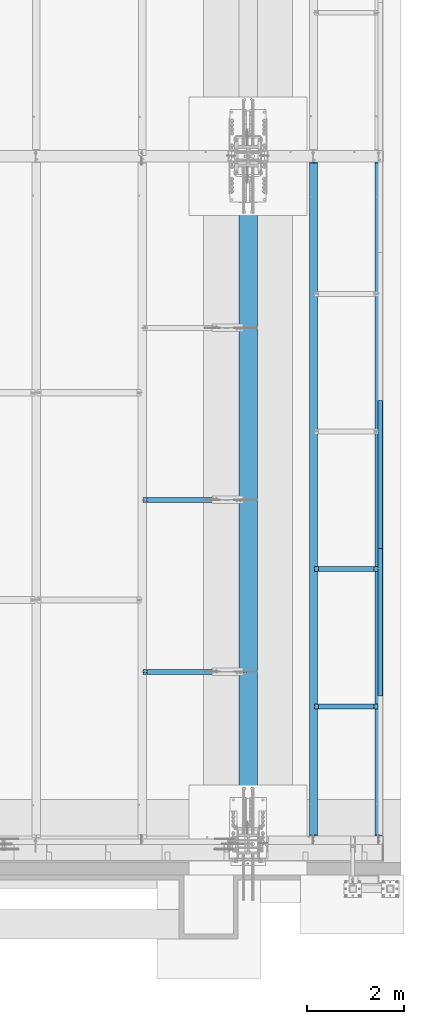
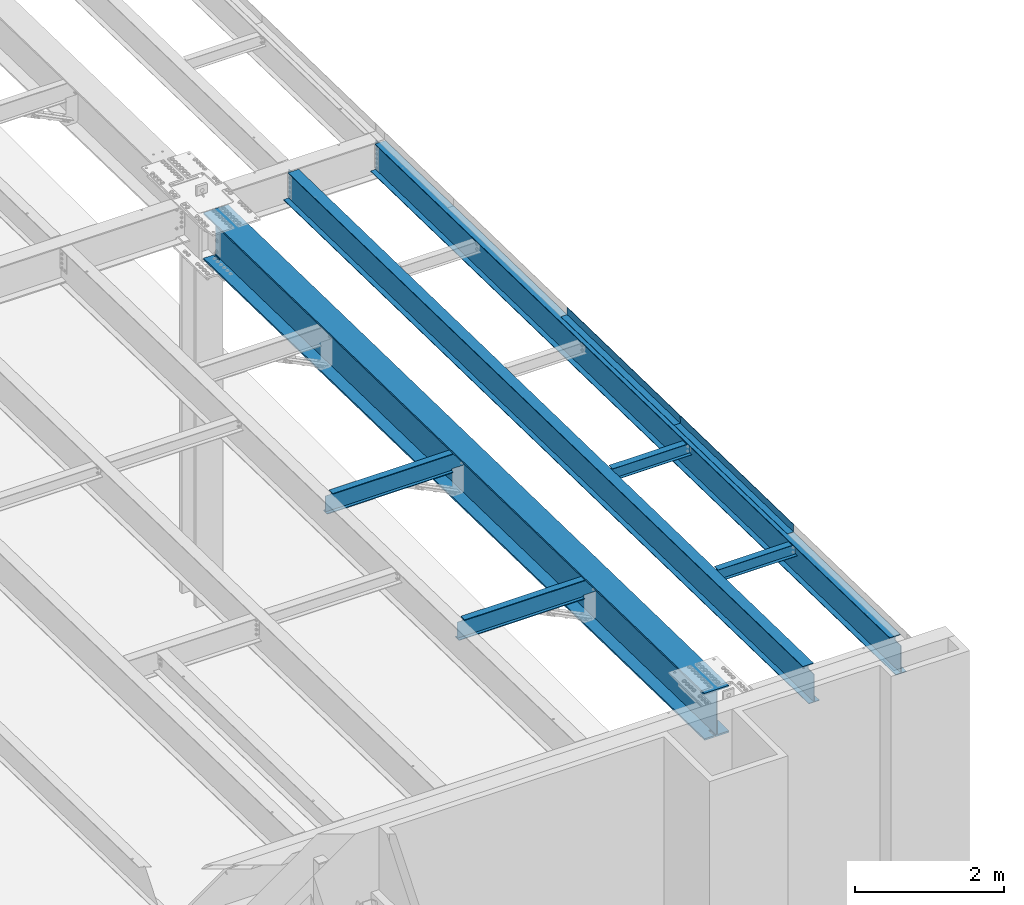
# One storey, part 1113 of 1763: 9 beams, 7 elements without a shape of their own.
"""IFC2X3 building model written with IfcOpenShell, lengths in millimetres."""

from ifc_helpers import new_model, si_unit, frame, origin_with_axes, place, context, subcontext, project, spatial, faceted_brep, material, type_object, element, aggregate, save


model = new_model("IFC2X3")

# Units and contexts
model_context = context("Model", 3, precision=1e-05, world=origin_with_axes())
body_context = subcontext(model_context, "Body", "Model", "MODEL_VIEW")
ifc_project = project(units=[si_unit("LENGTHUNIT", "METRE", prefix="MILLI"), si_unit("AREAUNIT", "SQUARE_METRE"), si_unit("VOLUMEUNIT", "CUBIC_METRE"), si_unit("MASSUNIT", "GRAM", prefix="KILO"), si_unit("TIMEUNIT", "SECOND"), si_unit("PLANEANGLEUNIT", "RADIAN"), si_unit("SOLIDANGLEUNIT", "STERADIAN"), si_unit("THERMODYNAMICTEMPERATUREUNIT", "DEGREE_CELSIUS"), si_unit("LUMINOUSINTENSITYUNIT", "LUMEN")], contexts=[model_context])

# Site, building, storey
site_placement = place(None, origin_with_axes())
site = spatial("IfcSite", under=ifc_project, at=site_placement, CompositionType="ELEMENT")
building_placement = place(site_placement, origin_with_axes())
building = spatial("IfcBuilding", under=site, at=building_placement, Name="Undefined", CompositionType="ELEMENT")
storey_placement = place(building_placement, origin_with_axes())
storey = spatial("IfcBuildingStorey", under=building, at=storey_placement, Name="Undefined", CompositionType="ELEMENT", Elevation=0.0)

# Assembly, beams
assembly_1_placement = place(storey_placement, origin_with_axes())
assembly_1 = element("IfcElementAssembly", 1, at=assembly_1_placement, inside=storey, Name="BEAM", AssemblyPlace="NOTDEFINED", PredefinedType="RIGID_FRAME")
ifc_material_1 = material(Name="STEEL/A36")
beam_type_1 = type_object("IfcBeamType", PredefinedType="NOTDEFINED")
beam_1_placement = place(assembly_1_placement, frame((-21348.1372736984, -6097.05363137779, 12048.5945885231), z_axis=(0.0, -0.999781542838788, 0.0209013539966307), x_axis=(1.0, 0.0, 0.0)))
beam_1 = element("IfcBeam", 2, at=beam_1_placement, type_object=beam_type_1, material=ifc_material_1, Name="BENT_PLATE", context=body_context, shape_type="Brep", body=[
    faceted_brep([(0.0, -3.17499999999927, -1523.99999999999), (0.0, -3.17499999999927, 1524.0), (0.0, 3.17499999999927, 1524.0), (0.0, 3.17499999999927, -1523.99999999999), (95.2499984741262, 3.17499999910251, 1523.99999999978), (95.2499984741262, 3.17500000090149, -1523.99999999977), (101.599998474125, -3.17499999909887, -1523.99999999978), (101.599999809252, -3.17500000000655, 1524.0), (95.2499984741262, 123.825003587437, 1523.99999999985), (95.2499984741262, 123.825003589236, -1523.9999999997), (101.599998474125, 123.825003587437, 1523.99999999985), (101.599998474125, 123.825003589236, -1523.9999999997)], [[[0, 1, 2, 3]], [[3, 2, 4, 5]], [[1, 0, 6, 7]], [[5, 4, 8, 9]], [[4, 2, 1, 7, 10, 8]], [[7, 6, 11, 10]], [[6, 0, 3, 5, 9, 11]], [[10, 11, 9, 8]]]),
])
beam_2_placement = place(assembly_1_placement, frame((-21348.1372736984, -9144.38777382545, 12112.3019215993), z_axis=(0.0, -0.999781542838788, 0.0209013539966307), x_axis=(1.0, 0.0, 0.0)))
beam_2 = element("IfcBeam", 3, at=beam_2_placement, type_object=beam_type_1, material=ifc_material_1, Name="BENT_PLATE", context=body_context, shape_type="Brep", body=[
    faceted_brep([(0.0, -3.17499999999927, -1523.99999999999), (0.0, -3.17499999999927, 1524.0), (0.0, 3.17499999999927, 1524.0), (0.0, 3.17499999999927, -1523.99999999999), (95.2499984741262, 3.17499999910251, 1523.99999999978), (95.2499984741262, 3.17500000090149, -1523.99999999977), (101.599998474125, -3.17499999909887, -1523.99999999978), (101.599999809252, -3.17500000000655, 1524.0), (95.2499984741262, 123.825003587437, 1523.99999999985), (95.2499984741262, 123.825003589236, -1523.9999999997), (101.599998474125, 123.825003587437, 1523.99999999985), (101.599998474125, 123.825003589236, -1523.9999999997)], [[[0, 1, 2, 3]], [[3, 2, 4, 5]], [[1, 0, 6, 7]], [[5, 4, 8, 9]], [[4, 2, 1, 7, 10, 8]], [[7, 6, 11, 10]], [[6, 0, 3, 5, 9, 11]], [[10, 11, 9, 8]]]),
])

# Assembly, beam
assembly_2_placement = place(storey_placement, origin_with_axes())
assembly_2 = element("IfcElementAssembly", 4, at=assembly_2_placement, inside=storey, Name="BEAM", AssemblyPlace="NOTDEFINED", PredefinedType="RIGID_FRAME")
ifc_material_2 = material(Name="STEEL/A992")
beam_type_2 = type_object("IfcBeamType", Name="W8X10", PredefinedType="NOTDEFINED")
beam_3_placement = place(assembly_2_placement, frame((-22678.4622736984, -10881.36, 12045.4267355389), z_axis=(0.0, 0.0, 1.0), x_axis=(1.0, 0.0, 0.0)))
beam_3 = element("IfcBeam", 5, at=beam_3_placement, type_object=beam_type_2, material=ifc_material_2, Name="BEAM", ObjectType="W8X10", context=body_context, shape_type="Brep", body=[
    faceted_brep([(1249.3625, -50.7999999999993, 100.012500000001), (1249.3625, -50.7999999999993, 95.25), (1249.3625, -2.38125000000036, 95.25), (1249.3625, -2.38125000000036, 87.0525014841896), (1249.3625, 2.38125000000036, 87.0525014841896), (1249.3625, 2.38125000000036, 95.25), (1249.3625, 50.7999999999993, 95.25), (1249.3625, 50.7999999999993, 100.012500000001), (1250.32922992258, -2.38125000000036, 82.1924219661432), (1250.32922992258, 2.38125000000036, 82.1924219661432), (1253.08224382306, -2.38125000000036, 78.0722454979896), (1253.08224382306, 2.38125000000036, 78.0722454979896), (1257.20242029121, -2.38125000000036, 75.319231597512), (1257.20242029121, 2.38125000000036, 75.319231597512), (1262.06249980926, -2.38125000000036, 74.3525016749245), (1262.06249980926, 2.38125000000036, 74.3525016749245), (1331.91249999999, -2.38125000000036, 74.3525016749245), (1331.91249999999, 2.38125000000036, 74.3525016749245), (100.012500000012, -50.7999999999993, 100.012500000001), (100.012500000012, 50.7999999999993, 100.012500000001), (100.012500000012, 50.7999999999993, 95.25), (100.012500000012, 2.38124999999854, 95.25), (100.012499999993, 2.38125000000036, 87.0525014841896), (100.012499999993, -2.38125000000036, 87.0525014841896), (100.012500000012, -2.38124999999854, 95.25), (100.012500000012, -50.7999999999993, 95.25), (99.0457700774059, 2.38125000000036, 82.1924219661432), (99.0457700774059, -2.38125000000036, 82.1924219661432), (96.2927561769284, 2.38125000000036, 78.0722454979896), (96.2927561769284, -2.38125000000036, 78.0722454979896), (92.1725797087747, 2.38125000000036, 75.319231597512), (92.1725797087747, -2.38125000000036, 75.319231597512), (87.3125001907283, 2.38125000000036, 74.3525016749245), (87.3125001907283, -2.38125000000036, 74.3525016749245), (17.4624999999978, 2.38125000000036, 74.3525016749245), (17.4624999999978, -2.38125000000036, 74.3525016749245), (17.462499935149, 2.38124999999854, -95.25), (17.4625000000015, 50.7999999999993, -95.25), (17.4625000000015, 50.7999999999993, -100.012500000001), (17.4624996160601, -50.8000000000029, -100.012500000001), (17.4624996160601, -50.8000000000029, -95.25), (17.4624999065727, -2.38124999999854, -95.25), (1331.91249999999, 2.38125000000036, -95.25), (1331.91249999999, 50.7999999999993, -95.25), (1331.91249999999, 50.7999999999993, -100.012500000001), (1331.91249999999, -50.7999999999993, -100.012500000001), (1331.91249999999, -50.7999999999993, -95.25), (1331.91249999999, -2.38125000000036, -95.25)], [[[0, 1, 2, 3, 4, 5, 6, 7]], [[8, 9, 4, 3]], [[10, 11, 9, 8]], [[12, 13, 11, 10]], [[14, 15, 13, 12]], [[16, 17, 15, 14]], [[18, 19, 20, 21, 22, 23, 24, 25]], [[23, 22, 26, 27]], [[27, 26, 28, 29]], [[29, 28, 30, 31]], [[31, 30, 32, 33]], [[33, 32, 34, 35]], [[36, 37, 38, 39, 40, 41, 35, 34]], [[37, 36, 42, 43]], [[38, 37, 43, 44]], [[39, 38, 44, 45]], [[40, 39, 45, 46]], [[41, 40, 46, 47]], [[12, 10, 8, 3, 2, 24, 23, 27, 29, 31, 33, 35, 41, 47, 16, 14]], [[25, 24, 2, 1]], [[18, 25, 1, 0]], [[19, 18, 0, 7]], [[20, 19, 7, 6]], [[21, 20, 6, 5]], [[42, 36, 34, 32, 30, 28, 26, 22, 21, 5, 4, 9, 11, 13, 15, 17]], [[47, 46, 45, 44, 43, 42, 17, 16]]]),
])
aggregate(assembly_2, [beam_3])

assembly_3_placement = place(storey_placement, origin_with_axes())
assembly_3 = element("IfcElementAssembly", 6, at=assembly_3_placement, inside=storey, Name="BEAM", AssemblyPlace="NOTDEFINED", PredefinedType="RIGID_FRAME")
beam_4_placement = place(assembly_3_placement, frame((-22678.4622736984, -8046.72, 11986.165969838), z_axis=(0.0, 0.0, 1.0), x_axis=(1.0, 0.0, 0.0)))
beam_4 = element("IfcBeam", 7, at=beam_4_placement, type_object=beam_type_2, material=ifc_material_2, Name="BEAM", ObjectType="W8X10", context=body_context, shape_type="Brep", body=[
    faceted_brep([(1249.3625, -50.7999999999993, 100.012500000001), (1249.3625, -50.7999999999993, 95.25), (1249.3625, -2.38125000000036, 95.25), (1249.3625, -2.38125000000036, 87.0525014841896), (1249.3625, 2.38125000000036, 87.0525014841896), (1249.3625, 2.38125000000036, 95.25), (1249.3625, 50.7999999999993, 95.25), (1249.3625, 50.7999999999993, 100.012500000001), (1250.32922992258, -2.38125000000036, 82.1924219661432), (1250.32922992258, 2.38125000000036, 82.1924219661432), (1253.08224382306, -2.38125000000036, 78.0722454979896), (1253.08224382306, 2.38125000000036, 78.0722454979896), (1257.20242029121, -2.38125000000036, 75.319231597512), (1257.20242029121, 2.38125000000036, 75.319231597512), (1262.06249980926, -2.38125000000036, 74.3525016749245), (1262.06249980926, 2.38125000000036, 74.3525016749245), (1331.91249999999, -2.38125000000036, 74.3525016749245), (1331.91249999999, 2.38125000000036, 74.3525016749245), (100.012500000012, -50.7999999999993, 100.012500000001), (100.012500000012, 50.7999999999993, 100.012500000001), (100.012500000012, 50.7999999999993, 95.25), (100.012500000012, 2.38124999999854, 95.25), (100.012499999993, 2.38125000000036, 87.0525014841896), (100.012499999993, -2.38125000000036, 87.0525014841896), (100.012500000012, -2.38124999999854, 95.25), (100.012500000012, -50.7999999999993, 95.25), (99.0457700774059, 2.38125000000036, 82.1924219661432), (99.0457700774059, -2.38125000000036, 82.1924219661432), (96.2927561769284, 2.38125000000036, 78.0722454979896), (96.2927561769284, -2.38125000000036, 78.0722454979896), (92.1725797087747, 2.38125000000036, 75.319231597512), (92.1725797087747, -2.38125000000036, 75.319231597512), (87.3125001907283, 2.38125000000036, 74.3525016749245), (87.3125001907283, -2.38125000000036, 74.3525016749245), (17.4624999999978, 2.38125000000036, 74.3525016749245), (17.4624999999978, -2.38125000000036, 74.3525016749245), (17.462499935149, 2.38124999999854, -95.25), (17.4625000000015, 50.7999999999993, -95.25), (17.4625000000015, 50.7999999999993, -100.012500000001), (17.4624996160601, -50.8000000000029, -100.012500000001), (17.4624996160601, -50.8000000000029, -95.25), (17.4624999065727, -2.38124999999854, -95.25), (1331.91249999999, 2.38125000000036, -95.25), (1331.91249999999, 50.7999999999993, -95.25), (1331.91249999999, 50.7999999999993, -100.012500000001), (1331.91249999999, -50.7999999999993, -100.012500000001), (1331.91249999999, -50.7999999999993, -95.25), (1331.91249999999, -2.38125000000036, -95.25)], [[[0, 1, 2, 3, 4, 5, 6, 7]], [[8, 9, 4, 3]], [[10, 11, 9, 8]], [[12, 13, 11, 10]], [[14, 15, 13, 12]], [[16, 17, 15, 14]], [[18, 19, 20, 21, 22, 23, 24, 25]], [[23, 22, 26, 27]], [[27, 26, 28, 29]], [[29, 28, 30, 31]], [[31, 30, 32, 33]], [[33, 32, 34, 35]], [[36, 37, 38, 39, 40, 41, 35, 34]], [[37, 36, 42, 43]], [[38, 37, 43, 44]], [[39, 38, 44, 45]], [[40, 39, 45, 46]], [[41, 40, 46, 47]], [[12, 10, 8, 3, 2, 24, 23, 27, 29, 31, 33, 35, 41, 47, 16, 14]], [[25, 24, 2, 1]], [[18, 25, 1, 0]], [[19, 18, 0, 7]], [[20, 19, 7, 6]], [[21, 20, 6, 5]], [[42, 36, 34, 32, 30, 28, 26, 22, 21, 5, 4, 9, 11, 13, 15, 17]], [[47, 46, 45, 44, 43, 42, 17, 16]]]),
])
aggregate(assembly_3, [beam_4])

assembly_4_placement = place(storey_placement, origin_with_axes())
assembly_4 = element("IfcElementAssembly", 8, at=assembly_4_placement, inside=storey, Name="BEAM", AssemblyPlace="NOTDEFINED", PredefinedType="RIGID_FRAME")
beam_type_3 = type_object("IfcBeamType", Name="W12X22", PredefinedType="NOTDEFINED")
beam_5_placement = place(assembly_4_placement, frame((-26212.2372736983, -6629.39997033327, 11900.9730863672), z_axis=(0.0, 0.0, 1.0), x_axis=(1.0, 0.0, 0.0)))
beam_5 = element("IfcBeam", 9, at=beam_5_placement, type_object=beam_type_3, material=ifc_material_2, Name="BEAM", ObjectType="W12X22", context=body_context, shape_type="Brep", body=[
    faceted_brep([(1973.26249999999, -3.17499999999927, -144.4625), (1973.26249999999, -50.7999999999993, -144.4625), (1973.26249999999, -50.7999999999993, -155.575000000001), (1973.26249999999, 50.7999999999993, -155.575000000001), (1973.26249999999, 50.7999999999993, -144.4625), (1973.26249999999, 3.17499999999927, -144.4625), (1973.26249999999, 3.17499999999927, -136.524999809046), (1973.26249999999, -3.17499999999927, -136.524999809046), (1974.22922992258, 3.17499999999927, -131.664920290999), (1974.22922992258, -3.17499999999927, -131.664920290999), (1976.98224382305, 3.17499999999927, -127.544743822846), (1976.98224382305, -3.17499999999927, -127.544743822846), (1981.10242029121, 3.17499999999927, -124.791729922368), (1981.10242029121, -3.17499999999927, -124.791729922368), (1985.96249980925, 3.17499999999927, -123.824999999781), (1985.96249980925, -3.17499999999927, -123.824999999781), (2163.76249999999, -3.17499999999927, -123.824999999781), (2163.76249999999, 3.17499999999927, -123.824999999781), (106.362499999999, 3.17500000000018, 144.4625), (106.362499999999, 50.8000000000002, 144.4625), (1973.26249999999, 50.7999999999993, 144.4625), (1973.26249999999, 3.17499999999927, 144.4625), (17.4624999999978, 3.17500000000018, -144.4625), (17.4624999999978, 50.8000000000002, -144.4625), (17.4624999999978, 50.8000000000002, -155.575000000001), (17.4624999999978, -50.8000000000002, -155.575000000001), (17.4624999999978, -50.8000000000002, -144.4625), (17.4624999999978, -3.17500000000018, -144.4625), (17.4624999999978, -3.17500000000018, 117.215001688795), (17.4624999999978, 3.17500000000018, 117.215001688795), (93.6625001907341, -3.17500000000018, 117.215001688795), (93.6625001907341, 3.17500000000018, 117.215001688795), (98.5225797087805, -3.17500000000018, 118.181731611383), (98.5225797087805, 3.17500000000018, 118.181731611383), (102.642756176934, -3.17500000000018, 120.93474551186), (102.642756176934, 3.17500000000018, 120.93474551186), (105.395770077412, -3.17500000000018, 125.054921980014), (105.395770077412, 3.17500000000018, 125.054921980014), (106.362499999999, -3.17500000000018, 129.915001498061), (106.362499999999, 3.17500000000018, 129.915001498061), (106.362499999999, -50.8000000000002, 155.575000000001), (106.362499999999, 50.8000000000002, 155.575000000001), (106.362499999999, -3.17500000000018, 144.4625), (106.362499999999, -50.8000000000002, 144.4625), (1973.26249999999, -3.17499999999927, 144.4625), (1973.26249999999, -50.7999999999993, 144.4625), (1973.26249999999, -50.7999999999993, 155.575000000001), (1973.26249999999, 50.7999999999993, 155.575000000001), (1973.26249999999, -3.17499999999927, 123.824999809485), (1973.26249999999, 3.17499999999927, 123.824999809485), (1974.22922992258, -3.17499999999927, 118.964920291439), (1974.22922992258, 3.17499999999927, 118.964920291439), (1976.98224382305, -3.17499999999927, 114.844743823285), (1976.98224382305, 3.17499999999927, 114.844743823285), (1981.10242029121, -3.17499999999927, 112.091729922808), (1981.10242029121, 3.17499999999927, 112.091729922808), (1985.96249980925, -3.17499999999927, 111.12500000022), (1985.96249980925, 3.17499999999927, 111.12500000022), (2163.76249999999, -3.17499999999927, 111.12500000022), (2163.76249999999, 3.17499999999927, 111.12500000022)], [[[0, 1, 2, 3, 4, 5, 6, 7]], [[7, 6, 8, 9]], [[9, 8, 10, 11]], [[11, 10, 12, 13]], [[13, 12, 14, 15]], [[16, 15, 14, 17]], [[18, 19, 20, 21]], [[22, 23, 24, 25, 26, 27, 28, 29]], [[30, 31, 29, 28]], [[32, 33, 31, 30]], [[34, 35, 33, 32]], [[36, 37, 35, 34]], [[38, 39, 37, 36]], [[40, 41, 19, 18, 39, 38, 42, 43]], [[43, 42, 44, 45]], [[40, 43, 45, 46]], [[41, 40, 46, 47]], [[19, 41, 47, 20]], [[46, 45, 44, 48, 49, 21, 20, 47]], [[50, 51, 49, 48]], [[52, 53, 51, 50]], [[54, 55, 53, 52]], [[56, 57, 55, 54]], [[58, 59, 57, 56]], [[59, 58, 16, 17]], [[12, 10, 8, 6, 5, 22, 29, 31, 33, 35, 37, 39, 18, 21, 49, 51, 53, 55, 57, 59, 17, 14]], [[23, 22, 5, 4]], [[24, 23, 4, 3]], [[25, 24, 3, 2]], [[26, 25, 2, 1]], [[27, 26, 1, 0]], [[58, 56, 54, 52, 50, 48, 44, 42, 38, 36, 34, 32, 30, 28, 27, 0, 7, 9, 11, 13, 15, 16]]]),
])
aggregate(assembly_4, [beam_5])

assembly_5_placement = place(storey_placement, origin_with_axes())
assembly_5 = element("IfcElementAssembly", 10, at=assembly_5_placement, inside=storey, Name="BEAM", AssemblyPlace="NOTDEFINED", PredefinedType="RIGID_FRAME")
beam_6_placement = place(assembly_5_placement, frame((-26212.2372736983, -10172.7, 11975.0490441136), z_axis=(0.0, 0.0, 1.0), x_axis=(1.0, 0.0, 0.0)))
beam_6 = element("IfcBeam", 11, at=beam_6_placement, type_object=beam_type_3, material=ifc_material_2, Name="BEAM", ObjectType="W12X22", context=body_context, shape_type="Brep", body=[
    faceted_brep([(1973.26249999999, -3.17499999999927, -144.4625), (1973.26249999999, -50.7999999999993, -144.4625), (1973.26249999999, -50.7999999999993, -155.575000000001), (1973.26249999999, 50.7999999999993, -155.575000000001), (1973.26249999999, 50.7999999999993, -144.4625), (1973.26249999999, 3.17499999999927, -144.4625), (1973.26249999999, 3.17499999999927, -136.524999809046), (1973.26249999999, -3.17499999999927, -136.524999809046), (1974.22922992258, 3.17499999999927, -131.664920290999), (1974.22922992258, -3.17499999999927, -131.664920290999), (1976.98224382305, 3.17499999999927, -127.544743822846), (1976.98224382305, -3.17499999999927, -127.544743822846), (1981.10242029121, 3.17499999999927, -124.791729922368), (1981.10242029121, -3.17499999999927, -124.791729922368), (1985.96249980925, 3.17499999999927, -123.824999999781), (1985.96249980925, -3.17499999999927, -123.824999999781), (2163.76249999999, -3.17499999999927, -123.824999999781), (2163.76249999999, 3.17499999999927, -123.824999999781), (106.362499999999, 3.17500000000018, 144.4625), (106.362499999999, 50.8000000000002, 144.4625), (1973.26249999999, 50.7999999999993, 144.4625), (1973.26249999999, 3.17499999999927, 144.4625), (17.4624999999978, 3.17500000000018, -144.4625), (17.4624999999978, 50.8000000000002, -144.4625), (17.4624999999978, 50.8000000000002, -155.575000000001), (17.4624999999978, -50.8000000000002, -155.575000000001), (17.4624999999978, -50.8000000000002, -144.4625), (17.4624999999978, -3.17500000000018, -144.4625), (17.4624999999978, -3.17500000000018, 117.215001688795), (17.4624999999978, 3.17500000000018, 117.215001688795), (93.6625001907341, -3.17500000000018, 117.215001688795), (93.6625001907341, 3.17500000000018, 117.215001688795), (98.5225797087805, -3.17500000000018, 118.181731611383), (98.5225797087805, 3.17500000000018, 118.181731611383), (102.642756176934, -3.17500000000018, 120.93474551186), (102.642756176934, 3.17500000000018, 120.93474551186), (105.395770077412, -3.17500000000018, 125.054921980014), (105.395770077412, 3.17500000000018, 125.054921980014), (106.362499999999, -3.17500000000018, 129.915001498061), (106.362499999999, 3.17500000000018, 129.915001498061), (106.362499999999, -50.8000000000002, 155.575000000001), (106.362499999999, 50.8000000000002, 155.575000000001), (106.362499999999, -3.17500000000018, 144.4625), (106.362499999999, -50.8000000000002, 144.4625), (1973.26249999999, -3.17499999999927, 144.4625), (1973.26249999999, -50.7999999999993, 144.4625), (1973.26249999999, -50.7999999999993, 155.575000000001), (1973.26249999999, 50.7999999999993, 155.575000000001), (1973.26249999999, -3.17499999999927, 123.824999809485), (1973.26249999999, 3.17499999999927, 123.824999809485), (1974.22922992258, -3.17499999999927, 118.964920291439), (1974.22922992258, 3.17499999999927, 118.964920291439), (1976.98224382305, -3.17499999999927, 114.844743823285), (1976.98224382305, 3.17499999999927, 114.844743823285), (1981.10242029121, -3.17499999999927, 112.091729922808), (1981.10242029121, 3.17499999999927, 112.091729922808), (1985.96249980925, -3.17499999999927, 111.12500000022), (1985.96249980925, 3.17499999999927, 111.12500000022), (2163.76249999999, -3.17499999999927, 111.12500000022), (2163.76249999999, 3.17499999999927, 111.12500000022)], [[[0, 1, 2, 3, 4, 5, 6, 7]], [[7, 6, 8, 9]], [[9, 8, 10, 11]], [[11, 10, 12, 13]], [[13, 12, 14, 15]], [[16, 15, 14, 17]], [[18, 19, 20, 21]], [[22, 23, 24, 25, 26, 27, 28, 29]], [[30, 31, 29, 28]], [[32, 33, 31, 30]], [[34, 35, 33, 32]], [[36, 37, 35, 34]], [[38, 39, 37, 36]], [[40, 41, 19, 18, 39, 38, 42, 43]], [[43, 42, 44, 45]], [[40, 43, 45, 46]], [[41, 40, 46, 47]], [[19, 41, 47, 20]], [[46, 45, 44, 48, 49, 21, 20, 47]], [[50, 51, 49, 48]], [[52, 53, 51, 50]], [[54, 55, 53, 52]], [[56, 57, 55, 54]], [[58, 59, 57, 56]], [[59, 58, 16, 17]], [[12, 10, 8, 6, 5, 22, 29, 31, 33, 35, 37, 39, 18, 21, 49, 51, 53, 55, 57, 59, 17, 14]], [[23, 22, 5, 4]], [[24, 23, 4, 3]], [[25, 24, 3, 2]], [[26, 25, 2, 1]], [[27, 26, 1, 0]], [[58, 56, 54, 52, 50, 48, 44, 42, 38, 36, 34, 32, 30, 28, 27, 0, 7, 9, 11, 13, 15, 16]]]),
])
aggregate(assembly_5, [beam_6])

assembly_6_placement = place(storey_placement, origin_with_axes())
assembly_6 = element("IfcElementAssembly", 12, at=assembly_6_placement, inside=storey, Name="BEAM", AssemblyPlace="NOTDEFINED", PredefinedType="RIGID_FRAME")
beam_type_4 = type_object("IfcBeamType", Name="W30X173", PredefinedType="NOTDEFINED")
beam_7_placement = place(assembly_6_placement, frame((-24027.8372736984, -13724.0960810468, 11817.4346193994), z_axis=(0.0, 0.0209013539966291, 0.999781542838788), x_axis=(0.0, 0.999781542776098, -0.0209013569953182)))
beam_7 = element("IfcBeam", 13, at=beam_7_placement, type_object=beam_type_4, material=ifc_material_2, Name="BEAM", ObjectType="W30X173", context=body_context, shape_type="Brep", body=[
    faceted_brep([(13805.0580356799, 41.275000381469, -387.350000004859), (13804.4938370817, 41.275000381469, -360.362500004836), (13666.9455328936, 41.275000381469, -360.36250000479), (13666.945529789, 41.275000381469, -387.350000004815), (13662.6929631785, 40.4291116719833, -360.36250000479), (13662.6929600739, 40.4291116719833, -387.350000004813), (13659.0878086528, 38.0202244315406, -360.36250000479), (13659.0878055482, 38.0202244315406, -387.35000000481), (13656.6789214123, 34.415069905881, -360.362500004789), (13656.6789183078, 34.415069905881, -387.35000000481), (13655.8330327029, 30.1625001907341, -360.362500004787), (13655.8330295983, 30.1625001907341, -387.35000000481), (13656.6789214123, 25.9099304755873, -360.362500004789), (13656.6789183078, 25.9099304755873, -387.35000000481), (13659.0878086528, 22.3047759499277, -360.36250000479), (13659.0878055482, 22.3047759499277, -387.35000000481), (13662.6929631785, 19.895888709485, -360.36250000479), (13662.6929600739, 19.895888709485, -387.350000004813), (13666.9455328936, 19.0499999999993, -360.36250000479), (13666.945529789, 19.0499999999993, -387.350000004815), (13805.058035702, 19.0499999999993, -387.350000004859), (13804.4938370817, 19.0499999999993, -360.362500004836), (318.910482335674, -7.9375, -360.362500000392), (318.910482335674, -190.5, -360.362500000392), (13804.4938370817, -190.5, -360.362500004836), (13804.4938370817, -7.9375, -360.362500004836), (303.843076811769, -7.9375, 360.362500000192), (13789.4264156949, -7.9375, 360.362499995746), (303.843076811769, -190.5, 360.362500000192), (13789.4264156949, -190.5, 360.362499995746), (303.27887880757, -190.5, 387.350000000211), (13788.8622170967, -190.5, 387.349999995769), (303.27887880757, 190.5, 387.350000000211), (13788.8622170967, 190.5, 387.349999995769), (303.843076811769, 190.5, 360.362500000192), (13789.4264156949, 190.5, 360.362499995746), (303.843076811769, 7.9375, 360.362500000192), (13789.4264156949, 7.9375, 360.362499995746), (318.910482335674, 7.9375, -360.362500000392), (13804.4938370817, 7.9375, -360.362500004836), (319.474680339874, 190.5, -387.350000000415), (318.910482335674, 190.5, -360.362500000392), (13804.4938370817, 190.5, -360.362500004836), (13805.0580356799, 190.5, -387.350000004859), (319.474680339874, 41.275000381469, -387.350000000415), (318.910482335674, 41.275000381469, -360.362500000392), (457.022988249291, 41.275000381469, -387.350000000459), (457.0229882493, 41.275000381469, -360.362500000441), (461.275557964449, 40.4291116719833, -387.350000000462), (461.27555796446, 40.4291116719833, -360.362500000441), (464.880712490116, 38.0202244315406, -387.350000000464), (464.880712490125, 38.0202244315406, -360.362500000441), (467.289599730566, 34.415069905881, -387.350000000464), (467.289599730571, 34.415069905881, -360.362500000443), (468.135488440053, 30.1625001907341, -387.350000000464), (468.135488440063, 30.1625001907341, -360.362500000441), (467.289599730566, 25.9099304755873, -387.350000000464), (467.289599730571, 25.9099304755873, -360.362500000443), (464.880712490116, 22.3047759499277, -387.350000000464), (464.880712490125, 22.3047759499277, -360.362500000441), (461.275557964449, 19.895888709485, -387.350000000462), (461.27555796446, 19.895888709485, -360.362500000441), (457.022988249291, 19.0499999999993, -387.350000000459), (457.0229882493, 19.0499999999993, -360.362500000441), (319.474680339874, 19.0499999999993, -387.350000000415), (318.910482335674, 19.0499999999993, -360.362500000392), (319.474680339874, -190.5, -387.350000000415), (13805.0580356799, -190.5, -387.350000004859)], [[[0, 1, 2, 3]], [[4, 5, 3, 2]], [[6, 7, 5, 4]], [[8, 9, 7, 6]], [[10, 11, 9, 8]], [[12, 13, 11, 10]], [[14, 15, 13, 12]], [[16, 17, 15, 14]], [[18, 19, 17, 16]], [[20, 19, 18, 21]], [[22, 23, 24, 25]], [[26, 22, 25, 27]], [[28, 26, 27, 29]], [[30, 28, 29, 31]], [[32, 30, 31, 33]], [[34, 32, 33, 35]], [[36, 34, 35, 37]], [[38, 36, 37, 39]], [[40, 41, 42, 43]], [[41, 40, 44, 45]], [[45, 44, 46, 47]], [[47, 46, 48, 49]], [[49, 48, 50, 51]], [[51, 50, 52, 53]], [[53, 52, 54, 55]], [[55, 54, 56, 57]], [[57, 56, 58, 59]], [[59, 58, 60, 61]], [[61, 60, 62, 63]], [[63, 62, 64, 65]], [[66, 23, 22, 26, 28, 30, 32, 34, 36, 38, 65, 64]], [[23, 66, 67, 24]], [[39, 37, 35, 33, 31, 29, 27, 25, 24, 67, 20, 21]], [[16, 14, 12, 10, 8, 6, 4, 2, 1, 42, 41, 45, 47, 49, 51, 53, 55, 57, 59, 61, 63, 65, 38, 39, 21, 18]], [[43, 42, 1, 0]], [[67, 66, 64, 62, 60, 58, 56, 54, 52, 50, 48, 46, 44, 40, 43, 0, 3, 5, 7, 9, 11, 13, 15, 17, 19, 20]]]),
])
aggregate(assembly_6, [beam_7])

# Beam
beam_type_5 = type_object("IfcBeamType", Name="W21X44", PredefinedType="NOTDEFINED")
beam_8_placement = place(assembly_1_placement, frame((-21329.0872736984, -13721.4747897009, 11942.8197221348), z_axis=(0.0, 0.0209013539966291, 0.999781542838788), x_axis=(0.0, 0.999781542776098, -0.0209013569953182)))
beam_8 = element("IfcBeam", 14, at=beam_8_placement, type_object=beam_type_5, material=ifc_material_2, Name="BEAM", ObjectType="W21X44", context=body_context, shape_type="Brep", body=[
    faceted_brep([(14036.5126611095, -82.5499999999993, 261.937499995587), (14036.5126611095, -82.5499999999993, 250.824999995577), (14036.5126611095, -4.76250000000073, 250.824999995577), (14036.5126611096, -4.76250000000073, 236.277501365199), (14036.5126611096, 4.76250000000073, 236.277501365199), (14036.5126611095, 4.76250000000073, 250.824999995577), (14036.5126611095, 82.5499999999993, 250.824999995577), (14036.5126611095, 82.5499999999993, 261.937499995587), (14037.4793910322, -4.76250000000073, 231.417421847142), (14037.4793910322, 4.76250000000073, 231.417421847142), (14040.2324049326, -4.76250000000073, 227.297245378979), (14040.2324049326, 4.76250000000073, 227.297245378979), (14044.3525814008, -4.76250000000073, 224.544231478496), (14044.3525814008, 4.76250000000073, 224.544231478496), (14049.2126609188, -4.76250000000073, 223.577501555901), (14049.2126609188, 4.76250000000073, 223.577501555901), (14158.8385670422, -4.76250000000073, 223.577501555903), (14158.8385670422, 4.76250000000073, 223.577501555903), (182.487793980217, -82.5499999999993, 261.937500000151), (182.487793980217, 82.5499999999993, 261.937500000151), (182.487793980215, 82.5499999999993, 250.825000000143), (182.487793980215, 4.76250000000073, 250.825000000143), (182.487793980201, 4.76250000000073, 210.877497673422), (182.487793980201, -4.76250000000073, 210.877497673422), (182.487793980215, -4.76250000000073, 250.825000000143), (182.487793980215, -82.5499999999993, 250.825000000143), (181.521064057606, 4.76250000000073, 206.017418155367), (181.521064057606, -4.76250000000073, 206.017418155367), (178.768050157123, 4.76250000000073, 201.897241687202), (178.768050157123, -4.76250000000073, 201.897241687202), (174.647873688958, 4.76250000000073, 199.144227786717), (174.647873688958, -4.76250000000073, 199.144227786717), (169.787794170899, 4.76250000000073, 198.177497864132), (169.787794170899, -4.76250000000073, 198.177497864132), (25.9447104595929, 4.76250000000073, 198.177497864177), (25.9447104595929, -4.76250000000073, 198.177497864177), (35.3315221270623, 4.76250000000073, -250.825000000212), (35.3315221270623, 82.5499999999993, -250.825000000212), (35.5638391969023, 82.5499999999993, -261.937500000222), (35.5638391969023, -82.5499999999993, -261.937500000222), (35.3315221270623, -82.5499999999993, -250.825000000212), (35.3315221270623, -4.76250000000073, -250.825000000212), (14168.7563892323, 4.76250000000073, -250.82500000487), (14168.7563892323, 82.5499999999993, -250.82500000487), (14168.9887063021, 82.5499999999993, -261.937500004879), (14168.9887063021, -82.5499999999993, -261.937500004879), (14168.7563892323, -82.5499999999993, -250.82500000487), (14168.7563892323, -4.76250000000073, -250.82500000487)], [[[0, 1, 2, 3, 4, 5, 6, 7]], [[8, 9, 4, 3]], [[10, 11, 9, 8]], [[12, 13, 11, 10]], [[14, 15, 13, 12]], [[16, 17, 15, 14]], [[18, 19, 20, 21, 22, 23, 24, 25]], [[23, 22, 26, 27]], [[27, 26, 28, 29]], [[29, 28, 30, 31]], [[31, 30, 32, 33]], [[33, 32, 34, 35]], [[36, 37, 38, 39, 40, 41, 35, 34]], [[37, 36, 42, 43]], [[38, 37, 43, 44]], [[39, 38, 44, 45]], [[40, 39, 45, 46]], [[41, 40, 46, 47]], [[12, 10, 8, 3, 2, 24, 23, 27, 29, 31, 33, 35, 41, 47, 16, 14]], [[25, 24, 2, 1]], [[18, 25, 1, 0]], [[19, 18, 0, 7]], [[20, 19, 7, 6]], [[21, 20, 6, 5]], [[42, 36, 34, 32, 30, 28, 26, 22, 21, 5, 4, 9, 11, 13, 15, 17]], [[47, 46, 45, 44, 43, 42, 17, 16]]]),
])

aggregate(assembly_1, [beam_1, beam_2, beam_8])

# Assembly, beam
assembly_7_placement = place(storey_placement, origin_with_axes())
assembly_7 = element("IfcElementAssembly", 15, at=assembly_7_placement, inside=storey, Name="BEAM", AssemblyPlace="NOTDEFINED", PredefinedType="RIGID_FRAME")
beam_9_placement = place(assembly_7_placement, frame((-22678.4622736984, -13721.4747897009, 11942.8197221348), z_axis=(0.0, 0.0209013539966291, 0.999781542838788), x_axis=(0.0, 0.999781542776098, -0.0209013569953182)))
beam_9 = element("IfcBeam", 16, at=beam_9_placement, type_object=beam_type_5, material=ifc_material_2, Name="BEAM", ObjectType="W21X44", context=body_context, shape_type="Brep", body=[
    faceted_brep([(14036.5126611095, -82.5499999999993, 261.937499995587), (14036.5126611095, -82.5499999999993, 250.824999995577), (14036.5126611095, -4.76250000000073, 250.824999995577), (14036.5126611096, -4.76250000000073, 236.277501365199), (14036.5126611096, 4.76250000000073, 236.277501365199), (14036.5126611095, 4.76250000000073, 250.824999995577), (14036.5126611095, 82.5499999999993, 250.824999995577), (14036.5126611095, 82.5499999999993, 261.937499995587), (14037.4793910322, -4.76250000000073, 231.417421847142), (14037.4793910322, 4.76250000000073, 231.417421847142), (14040.2324049326, -4.76250000000073, 227.297245378979), (14040.2324049326, 4.76250000000073, 227.297245378979), (14044.3525814008, -4.76250000000073, 224.544231478496), (14044.3525814008, 4.76250000000073, 224.544231478496), (14049.2126609188, -4.76250000000073, 223.577501555901), (14049.2126609188, 4.76250000000073, 223.577501555901), (14158.8385670422, -4.76250000000073, 223.577501555903), (14158.8385670422, 4.76250000000073, 223.577501555903), (182.487793980217, -82.5499999999993, 261.937500000151), (182.487793980217, 82.5499999999993, 261.937500000151), (182.487793980215, 82.5499999999993, 250.825000000143), (182.487793980215, 4.76250000000073, 250.825000000143), (182.487793980201, 4.76250000000073, 210.877497673422), (182.487793980201, -4.76250000000073, 210.877497673422), (182.487793980215, -4.76250000000073, 250.825000000143), (182.487793980215, -82.5499999999993, 250.825000000143), (181.521064057606, 4.76250000000073, 206.017418155367), (181.521064057606, -4.76250000000073, 206.017418155367), (178.768050157123, 4.76250000000073, 201.897241687202), (178.768050157123, -4.76250000000073, 201.897241687202), (174.647873688958, 4.76250000000073, 199.144227786717), (174.647873688958, -4.76250000000073, 199.144227786717), (169.787794170899, 4.76250000000073, 198.177497864132), (169.787794170899, -4.76250000000073, 198.177497864132), (25.9447104595929, 4.76250000000073, 198.177497864177), (25.9447104595929, -4.76250000000073, 198.177497864177), (35.3315221270623, 4.76250000000073, -250.825000000212), (35.3315221270623, 82.5499999999993, -250.825000000212), (35.5638391969023, 82.5499999999993, -261.937500000222), (35.5638391969023, -82.5499999999993, -261.937500000222), (35.3315221270623, -82.5499999999993, -250.825000000212), (35.3315221270623, -4.76250000000073, -250.825000000212), (14168.7563892323, 4.76250000000073, -250.82500000487), (14168.7563892323, 82.5499999999993, -250.82500000487), (14168.9887063021, 82.5499999999993, -261.937500004879), (14168.9887063021, -82.5499999999993, -261.937500004879), (14168.7563892323, -82.5499999999993, -250.82500000487), (14168.7563892323, -4.76250000000073, -250.82500000487)], [[[0, 1, 2, 3, 4, 5, 6, 7]], [[8, 9, 4, 3]], [[10, 11, 9, 8]], [[12, 13, 11, 10]], [[14, 15, 13, 12]], [[16, 17, 15, 14]], [[18, 19, 20, 21, 22, 23, 24, 25]], [[23, 22, 26, 27]], [[27, 26, 28, 29]], [[29, 28, 30, 31]], [[31, 30, 32, 33]], [[33, 32, 34, 35]], [[36, 37, 38, 39, 40, 41, 35, 34]], [[37, 36, 42, 43]], [[38, 37, 43, 44]], [[39, 38, 44, 45]], [[40, 39, 45, 46]], [[41, 40, 46, 47]], [[12, 10, 8, 3, 2, 24, 23, 27, 29, 31, 33, 35, 41, 47, 16, 14]], [[25, 24, 2, 1]], [[18, 25, 1, 0]], [[19, 18, 0, 7]], [[20, 19, 7, 6]], [[21, 20, 6, 5]], [[42, 36, 34, 32, 30, 28, 26, 22, 21, 5, 4, 9, 11, 13, 15, 17]], [[47, 46, 45, 44, 43, 42, 17, 16]]]),
])
aggregate(assembly_7, [beam_9])

save(model, "model.ifc")
